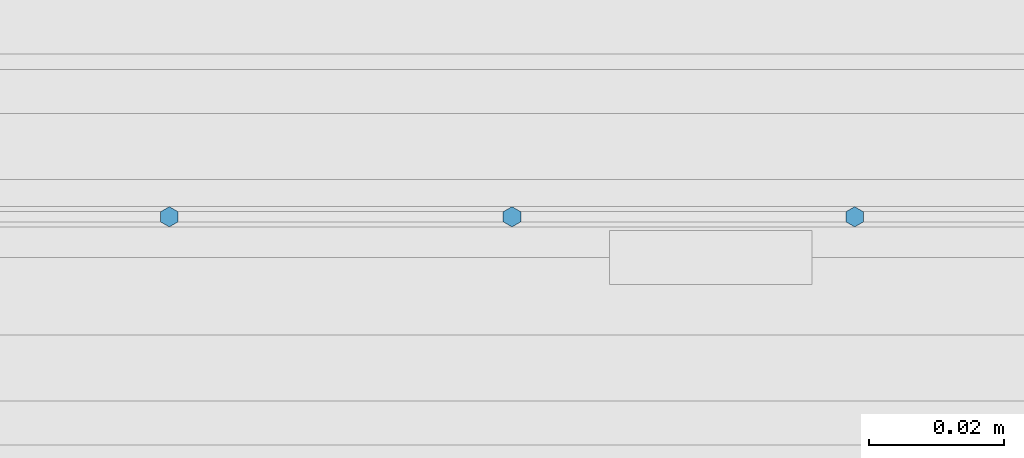
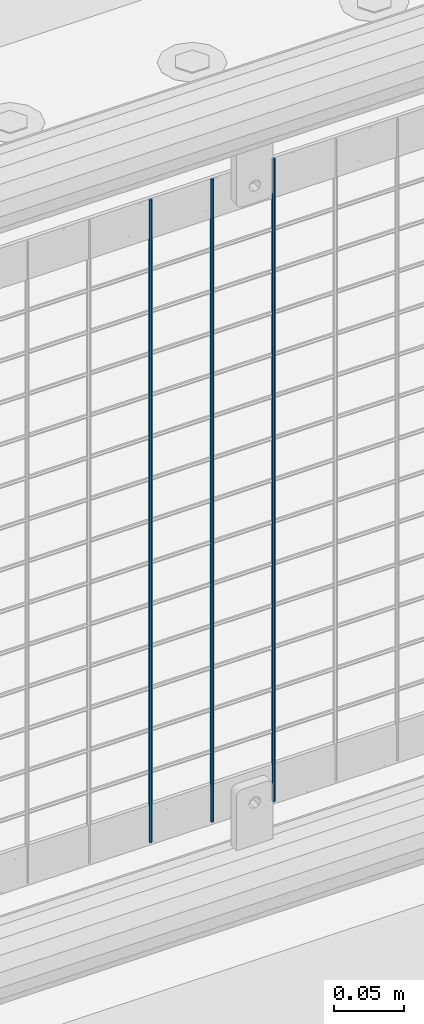
# One storey, part 63 of 242: 3 columns.
"""IFC2X3 building model written with IfcOpenShell, lengths in millimetres."""

from ifc_helpers import new_model, si_unit, frame, origin_with_axes, place, context, subcontext, project, spatial, faceted_brep, material, type_object, element, save


model = new_model("IFC2X3")

# Units and contexts
model_context = context("Model", 3, precision=1e-05, world=origin_with_axes())
body_context = subcontext(model_context, "Body", "Model", "MODEL_VIEW")
ifc_project = project(units=[si_unit("LENGTHUNIT", "METRE", prefix="MILLI"), si_unit("AREAUNIT", "SQUARE_METRE"), si_unit("VOLUMEUNIT", "CUBIC_METRE"), si_unit("MASSUNIT", "GRAM", prefix="KILO"), si_unit("TIMEUNIT", "SECOND"), si_unit("PLANEANGLEUNIT", "RADIAN"), si_unit("SOLIDANGLEUNIT", "STERADIAN"), si_unit("THERMODYNAMICTEMPERATUREUNIT", "DEGREE_CELSIUS"), si_unit("LUMINOUSINTENSITYUNIT", "LUMEN")], contexts=[model_context])

# Site, building, storey
site_placement = place(None, origin_with_axes())
site = spatial("IfcSite", under=ifc_project, at=site_placement, CompositionType="ELEMENT")
building_placement = place(site_placement, origin_with_axes())
building = spatial("IfcBuilding", under=site, at=building_placement, Name="Standard", CompositionType="ELEMENT")
storey_placement = place(building_placement, origin_with_axes())
storey = spatial("IfcBuildingStorey", under=building, at=storey_placement, Name="Undefined", CompositionType="ELEMENT", Elevation=0.0)

# Columns
ifc_material = material(Name="Misc_Undefined")
column_type = type_object("IfcColumnType", Name="D3", PredefinedType="NOTDEFINED")
for number, where, z_axis, x_axis in (
    (1, (-41342.656, -19329.5, 353.02), (-1.0, 0.0, 0.0), (0.0, 0.0, 1.0)),
    (2, (-41393.449, -19329.5, 353.02), (-1.0, 0.0, 0.0), (0.0, 0.0, 1.0)),
    (3, (-41444.242, -19329.5, 353.02), (-1.0, 0.0, 0.0), (0.0, 0.0, 1.0)),
):
    element("IfcColumn", number, at=place(storey_placement, frame(where, z_axis=z_axis, x_axis=x_axis)), inside=storey, type_object=column_type, material=ifc_material, ObjectType="D3", context=body_context, shape_type="Brep", body=[
        faceted_brep([(0.0, -1.50000000000364, 0.0), (-3.63797880709171e-12, -0.750000000003638, -1.29903810567669), (560.0, -0.75, -1.29903810567703), (560.0, -1.5, 0.0), (0.0, 0.749999999996362, -1.29903810567669), (560.0, 0.75, -1.29903810567703), (-3.63797880709171e-12, 1.49999999999636, 0.0), (560.0, 1.5, 0.0), (0.0, 0.749999999996362, 1.29903810567669), (560.0, 0.75, 1.29903810567703), (-3.63797880709171e-12, -0.750000000003638, 1.29903810567669), (560.0, -0.75, 1.29903810567703)], [[[0, 1, 2, 3]], [[1, 4, 5, 2]], [[4, 6, 7, 5]], [[6, 8, 9, 7]], [[8, 10, 11, 9]], [[10, 0, 3, 11]], [[5, 7, 9, 11, 3, 2]], [[10, 8, 6, 4, 1, 0]]]),
    ])

save(model, "model.ifc")
